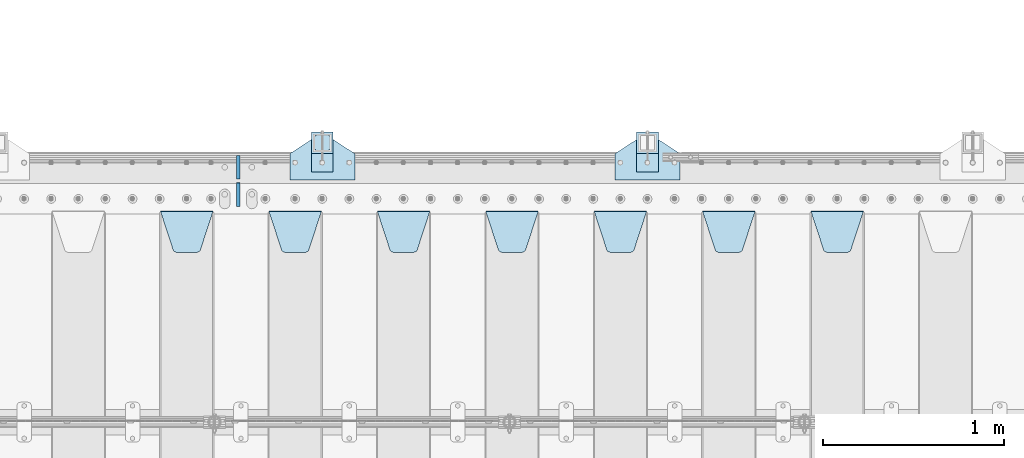
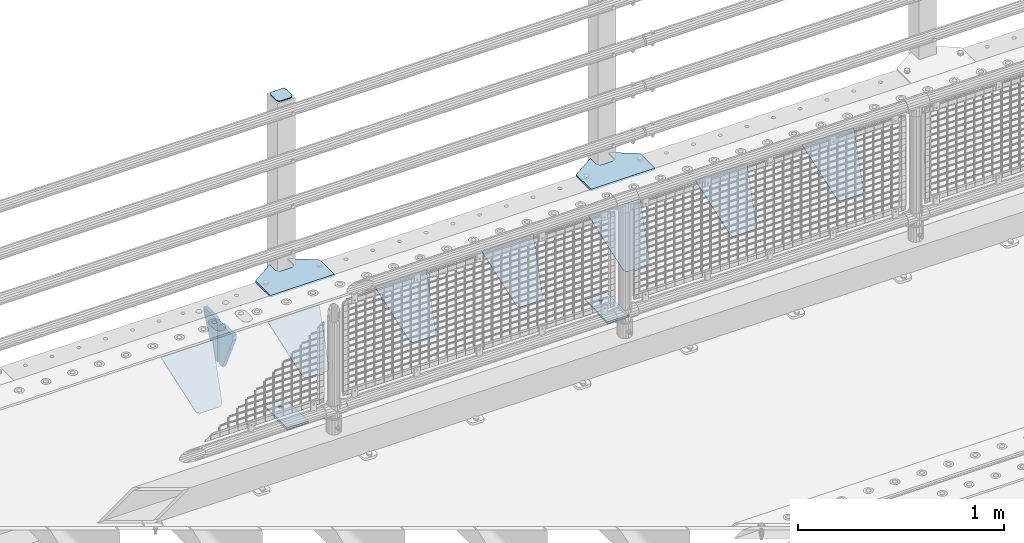
# One storey, part 212 of 242: 16 plates.
"""IFC2X3 building model written with IfcOpenShell, lengths in millimetres."""

from ifc_helpers import new_model, si_unit, frame, origin_with_axes, place, context, subcontext, project, spatial, faceted_brep, material, type_object, element, save


model = new_model("IFC2X3")

# Units and contexts
model_context = context("Model", 3, precision=1e-05, world=origin_with_axes())
body_context = subcontext(model_context, "Body", "Model", "MODEL_VIEW")
ifc_project = project(units=[si_unit("LENGTHUNIT", "METRE", prefix="MILLI"), si_unit("AREAUNIT", "SQUARE_METRE"), si_unit("VOLUMEUNIT", "CUBIC_METRE"), si_unit("MASSUNIT", "GRAM", prefix="KILO"), si_unit("TIMEUNIT", "SECOND"), si_unit("PLANEANGLEUNIT", "RADIAN"), si_unit("SOLIDANGLEUNIT", "STERADIAN"), si_unit("THERMODYNAMICTEMPERATUREUNIT", "DEGREE_CELSIUS"), si_unit("LUMINOUSINTENSITYUNIT", "LUMEN")], contexts=[model_context])

# Site, building, storey
site_placement = place(None, origin_with_axes())
site = spatial("IfcSite", under=ifc_project, at=site_placement, CompositionType="ELEMENT")
building_placement = place(site_placement, origin_with_axes())
building = spatial("IfcBuilding", under=site, at=building_placement, Name="Standard", CompositionType="ELEMENT")
storey_placement = place(building_placement, origin_with_axes())
storey = spatial("IfcBuildingStorey", under=building, at=storey_placement, Name="Undefined", CompositionType="ELEMENT", Elevation=0.0)

# Plates
ifc_material_1 = material(Name="STEEL/S355J2")
plate_type_1 = type_object("IfcPlateType", PredefinedType="NOTDEFINED")
plate_1_placement = place(storey_placement, frame((-33080.0, -17995.0, 5.00000000004911), z_axis=(0.0, 1.0, 0.0), x_axis=(1.0, 0.0, 0.0)))
element("IfcPlate", 1, at=plate_1_placement, inside=storey, type_object=plate_type_1, material=ifc_material_1, context=body_context, shape_type="Brep", body=[
    faceted_brep([(0.0, -5.0, 0.0), (2.31396552408114e-06, -5.0, 145.0), (2.31396552408114e-06, 5.0, 145.0), (0.0, 5.0, 0.0), (130.0, -5.0, 230.0), (130.0, 5.0, 230.0), (130.0, -5.0, 180.0), (130.0, 5.0, 180.0), (130.48036798992, -5.0, 175.122741949595), (130.48036798992, 5.0, 175.122741949595), (131.903011687216, -5.0, 170.432914190871), (131.903011687216, 5.0, 170.432914190871), (134.213259692435, -5.0, 166.110744174512), (134.213259692435, 5.0, 166.110744174512), (137.322330470335, -5.0, 162.322330470335), (137.322330470335, 5.0, 162.322330470335), (141.110744174512, -5.0, 159.213259692435), (141.110744174512, 5.0, 159.213259692435), (145.432914190871, -5.0, 156.903011687216), (145.432914190871, 5.0, 156.903011687216), (150.122741949595, -5.0, 155.48036798992), (150.122741949595, 5.0, 155.48036798992), (155.0, -5.0, 155.0), (155.0, 5.0, 155.0), (205.0, -5.0, 155.0), (205.0, 5.0, 155.0), (209.877258050405, -5.0, 155.48036798992), (209.877258050405, 5.0, 155.48036798992), (214.567085809129, -5.0, 156.903011687216), (214.567085809129, 5.0, 156.903011687216), (218.889255825488, -5.0, 159.213259692435), (218.889255825488, 5.0, 159.213259692435), (222.677669529665, -5.0, 162.322330470335), (222.677669529665, 5.0, 162.322330470335), (225.786740307565, -5.0, 166.110744174512), (225.786740307565, 5.0, 166.110744174512), (228.096988312784, -5.0, 170.432914190871), (228.096988312784, 5.0, 170.432914190871), (229.51963201008, -5.0, 175.122741949595), (229.51963201008, 5.0, 175.122741949595), (230.0, -5.0, 180.0), (230.0, 5.0, 180.0), (230.0, -5.0, 230.0), (230.0, 5.0, 230.0), (360.0, -5.0, 145.0), (360.0, 5.0, 145.0), (360.0, -5.0, -7.27595761418343e-12), (360.0, 5.0, -7.27595761418343e-12)], [[[0, 1, 2, 3]], [[1, 4, 5, 2]], [[4, 6, 7, 5]], [[6, 8, 9, 7]], [[8, 10, 11, 9]], [[10, 12, 13, 11]], [[12, 14, 15, 13]], [[14, 16, 17, 15]], [[16, 18, 19, 17]], [[18, 20, 21, 19]], [[20, 22, 23, 21]], [[22, 24, 25, 23]], [[24, 26, 27, 25]], [[26, 28, 29, 27]], [[28, 30, 31, 29]], [[30, 32, 33, 31]], [[32, 34, 35, 33]], [[34, 36, 37, 35]], [[36, 38, 39, 37]], [[38, 40, 41, 39]], [[40, 42, 43, 41]], [[42, 44, 45, 43]], [[44, 46, 47, 45]], [[46, 0, 3, 47]], [[5, 7, 9, 11, 13, 15, 17, 19, 21, 23, 25, 27, 29, 31, 33, 35, 37, 39, 41, 43, 45, 47, 3, 2]], [[46, 44, 42, 40, 38, 36, 34, 32, 30, 28, 26, 24, 22, 20, 18, 16, 14, 12, 10, 8, 6, 4, 1, 0]]]),
])
plate_2_placement = place(storey_placement, frame((-34880.0, -17995.0, 5.00000000004911), z_axis=(0.0, 1.0, 0.0), x_axis=(1.0, 0.0, 0.0)))
element("IfcPlate", 2, at=plate_2_placement, inside=storey, type_object=plate_type_1, material=ifc_material_1, context=body_context, shape_type="Brep", body=[
    faceted_brep([(0.0, -5.0, 0.0), (2.31396552408114e-06, -5.0, 145.0), (2.31396552408114e-06, 5.0, 145.0), (0.0, 5.0, 0.0), (130.0, -5.0, 230.0), (130.0, 5.0, 230.0), (130.0, -5.0, 180.0), (130.0, 5.0, 180.0), (130.48036798992, -5.0, 175.122741949595), (130.48036798992, 5.0, 175.122741949595), (131.903011687216, -5.0, 170.432914190871), (131.903011687216, 5.0, 170.432914190871), (134.213259692435, -5.0, 166.110744174512), (134.213259692435, 5.0, 166.110744174512), (137.322330470335, -5.0, 162.322330470335), (137.322330470335, 5.0, 162.322330470335), (141.110744174512, -5.0, 159.213259692435), (141.110744174512, 5.0, 159.213259692435), (145.432914190871, -5.0, 156.903011687216), (145.432914190871, 5.0, 156.903011687216), (150.122741949595, -5.0, 155.48036798992), (150.122741949595, 5.0, 155.48036798992), (155.0, -5.0, 155.0), (155.0, 5.0, 155.0), (205.0, -5.0, 155.0), (205.0, 5.0, 155.0), (209.877258050405, -5.0, 155.48036798992), (209.877258050405, 5.0, 155.48036798992), (214.567085809129, -5.0, 156.903011687216), (214.567085809129, 5.0, 156.903011687216), (218.889255825488, -5.0, 159.213259692435), (218.889255825488, 5.0, 159.213259692435), (222.677669529665, -5.0, 162.322330470335), (222.677669529665, 5.0, 162.322330470335), (225.786740307565, -5.0, 166.110744174512), (225.786740307565, 5.0, 166.110744174512), (228.096988312784, -5.0, 170.432914190871), (228.096988312784, 5.0, 170.432914190871), (229.51963201008, -5.0, 175.122741949595), (229.51963201008, 5.0, 175.122741949595), (230.0, -5.0, 180.0), (230.0, 5.0, 180.0), (230.0, -5.0, 230.0), (230.0, 5.0, 230.0), (360.0, -5.0, 145.0), (360.0, 5.0, 145.0), (360.0, -5.0, -7.27595761418343e-12), (360.0, 5.0, -7.27595761418343e-12)], [[[0, 1, 2, 3]], [[1, 4, 5, 2]], [[4, 6, 7, 5]], [[6, 8, 9, 7]], [[8, 10, 11, 9]], [[10, 12, 13, 11]], [[12, 14, 15, 13]], [[14, 16, 17, 15]], [[16, 18, 19, 17]], [[18, 20, 21, 19]], [[20, 22, 23, 21]], [[22, 24, 25, 23]], [[24, 26, 27, 25]], [[26, 28, 29, 27]], [[28, 30, 31, 29]], [[30, 32, 33, 31]], [[32, 34, 35, 33]], [[34, 36, 37, 35]], [[36, 38, 39, 37]], [[38, 40, 41, 39]], [[40, 42, 43, 41]], [[42, 44, 45, 43]], [[44, 46, 47, 45]], [[46, 0, 3, 47]], [[5, 7, 9, 11, 13, 15, 17, 19, 21, 23, 25, 27, 29, 31, 33, 35, 37, 39, 41, 43, 45, 47, 3, 2]], [[46, 44, 42, 40, 38, 36, 34, 32, 30, 28, 26, 24, 22, 20, 18, 16, 14, 12, 10, 8, 6, 4, 1, 0]]]),
])
plate_type_2 = type_object("IfcPlateType", PredefinedType="NOTDEFINED")
for number, where, z_axis, x_axis in (
    (3, (-32959.9999999999, -17949.9999999998, -850.000000000002), (0.0, 1.0, 0.0), (1.0, 0.0, 0.0)),
    (4, (-34759.9999999999, -17949.9999999998, -850.000000000002), (0.0, 1.0, 0.0), (1.0, 0.0, 0.0)),
):
    element("IfcPlate", number, at=place(storey_placement, frame(where, z_axis=z_axis, x_axis=x_axis)), inside=storey, type_object=plate_type_2, material=ifc_material_1, context=body_context, shape_type="Brep", body=[
        faceted_brep([(66.3639610305399, -5.0, 163.636038969114), (66.3639610305399, 5.0, 163.636038969114), (59.9999999998618, 5.0, 160.999999999793), (59.9999999998618, -5.0, 160.999999999793), (53.6360389691836, 5.0, 163.636038969114), (53.6360389691836, -5.0, 163.636038969114), (50.9999999998618, 5.0, 169.999999999793), (50.9999999998618, -5.0, 169.999999999793), (53.6360389691836, 5.0, 176.363961030471), (53.6360389691836, -5.0, 176.363961030471), (59.9999999998618, 5.0, 178.999999999793), (59.9999999998618, -5.0, 178.999999999793), (66.3639610305399, 5.0, 176.363961030471), (66.3639610305399, -5.0, 176.363961030471), (68.9999999998618, 5.0, 169.999999999793), (68.9999999998618, -5.0, 169.999999999793), (120.0, -5.0, 0.0), (120.0, -5.0, 220.0), (0.0, -5.0, 220.0), (0.0, -5.0, 0.0), (0.0, 5.0, 0.0), (120.0, 5.0, 0.0), (120.0, 5.0, 220.0), (0.0, 5.0, 220.0)], [[[0, 1, 2, 3]], [[3, 2, 4, 5]], [[5, 4, 6, 7]], [[7, 6, 8, 9]], [[9, 8, 10, 11]], [[11, 10, 12, 13]], [[13, 12, 14, 15]], [[15, 14, 1, 0]], [[16, 17, 18, 19], [11, 13, 15, 0, 3, 5, 7, 9]], [[16, 19, 20, 21]], [[17, 16, 21, 22]], [[18, 17, 22, 23]], [[19, 18, 23, 20]], [[22, 21, 20, 23], [2, 1, 14, 12, 10, 8, 6, 4]]]),
    ])
plate_type_3 = type_object("IfcPlateType", PredefinedType="NOTDEFINED")
plate_3_placement = place(storey_placement, frame((-34655.9999999999, -17833.9999999998, 1012.50000000001), z_axis=(0.0, 1.0, 0.0), x_axis=(-1.0, 0.0, 0.0)))
element("IfcPlate", 5, at=plate_3_placement, inside=storey, type_object=plate_type_3, material=ifc_material_1, context=body_context, shape_type="Brep", body=[
    faceted_brep([(0.0, -2.5, 19.0), (0.0, -2.5, 69.0), (0.0, 2.5, 69.0), (0.0, 2.5, 19.0), (0.476369668544066, -2.5, 73.2278977451715), (0.476369668544066, 2.5, 73.2278977451715), (1.88159150985302, -2.5, 77.2437910432345), (1.88159150985302, 2.5, 77.2437910432345), (4.14520183310742, -2.5, 80.8463062353148), (4.14520183310742, 2.5, 80.8463062353148), (7.15369376468516, -2.5, 83.8547981668926), (7.15369376468516, 2.5, 83.8547981668926), (10.7562089567655, -2.5, 86.118408490147), (10.7562089567655, 2.5, 86.118408490147), (14.7721022548285, -2.5, 87.5236303314559), (14.7721022548285, 2.5, 87.5236303314559), (19.0, -2.5, 88.0), (19.0, 2.5, 88.0), (69.0, -2.5, 88.0), (69.0, 2.5, 88.0), (73.2278977451715, -2.5, 87.5236303314559), (73.2278977451715, 2.5, 87.5236303314559), (77.2437910432345, -2.5, 86.118408490147), (77.2437910432345, 2.5, 86.118408490147), (80.8463062353148, -2.5, 83.8547981668926), (80.8463062353148, 2.5, 83.8547981668926), (83.8547981668926, -2.5, 80.8463062353148), (83.8547981668926, 2.5, 80.8463062353148), (86.118408490147, -2.5, 77.2437910432345), (86.118408490147, 2.5, 77.2437910432345), (87.5236303314559, -2.5, 73.2278977451715), (87.5236303314559, 2.5, 73.2278977451715), (88.0, -2.5, 69.0), (88.0, 2.5, 69.0), (88.0, -2.5, 19.0), (88.0, 2.5, 19.0), (87.5236303314559, -2.5, 14.7721022548285), (87.5236303314559, 2.5, 14.7721022548285), (86.118408490147, -2.5, 10.7562089567655), (86.118408490147, 2.5, 10.7562089567655), (83.8547981668926, -2.5, 7.15369376468516), (83.8547981668926, 2.5, 7.15369376468516), (80.8463062353148, -2.5, 4.14520183310742), (80.8463062353148, 2.5, 4.14520183310742), (77.2437910432345, -2.5, 1.88159150985302), (77.2437910432345, 2.5, 1.88159150985302), (73.2278977451715, -2.5, 0.476369668544066), (73.2278977451715, 2.5, 0.476369668544066), (69.0, -2.5, 0.0), (69.0, 2.5, 0.0), (19.0, -2.5, 0.0), (19.0, 2.5, 0.0), (14.7721022548285, -2.5, 0.476369668544066), (14.7721022548285, 2.5, 0.476369668544066), (10.7562089567655, -2.5, 1.88159150985302), (10.7562089567655, 2.5, 1.88159150985302), (7.15369376468516, -2.5, 4.14520183310742), (7.15369376468516, 2.5, 4.14520183310742), (4.14520183310742, -2.5, 7.15369376468516), (4.14520183310742, 2.5, 7.15369376468516), (1.88159150985302, -2.5, 10.7562089567655), (1.88159150985302, 2.5, 10.7562089567655), (0.476369668544066, -2.5, 14.7721022548285), (0.476369668544066, 2.5, 14.7721022548285)], [[[0, 1, 2, 3]], [[1, 4, 5, 2]], [[4, 6, 7, 5]], [[6, 8, 9, 7]], [[8, 10, 11, 9]], [[10, 12, 13, 11]], [[12, 14, 15, 13]], [[14, 16, 17, 15]], [[16, 18, 19, 17]], [[18, 20, 21, 19]], [[20, 22, 23, 21]], [[22, 24, 25, 23]], [[24, 26, 27, 25]], [[26, 28, 29, 27]], [[28, 30, 31, 29]], [[30, 32, 33, 31]], [[32, 34, 35, 33]], [[34, 36, 37, 35]], [[36, 38, 39, 37]], [[38, 40, 41, 39]], [[40, 42, 43, 41]], [[42, 44, 45, 43]], [[44, 46, 47, 45]], [[46, 48, 49, 47]], [[48, 50, 51, 49]], [[50, 52, 53, 51]], [[52, 54, 55, 53]], [[54, 56, 57, 55]], [[56, 58, 59, 57]], [[58, 60, 61, 59]], [[60, 62, 63, 61]], [[62, 0, 3, 63]], [[5, 7, 9, 11, 13, 15, 17, 19, 21, 23, 25, 27, 29, 31, 33, 35, 37, 39, 41, 43, 45, 47, 49, 51, 53, 55, 57, 59, 61, 63, 3, 2]], [[62, 60, 58, 56, 54, 52, 50, 48, 46, 44, 42, 40, 38, 36, 34, 32, 30, 28, 26, 24, 22, 20, 18, 16, 14, 12, 10, 8, 6, 4, 1, 0]]]),
])
plate_type_4 = type_object("IfcPlateType", PredefinedType="NOTDEFINED")
for number, where, z_axis, x_axis in (
    (6, (-32959.9999999999, -17949.9999999998, -857.500000000002), (0.0, 1.0, 0.0), (1.0, 0.0, 0.0)),
    (7, (-34759.9999999999, -17949.9999999998, -857.500000000002), (0.0, 1.0, 0.0), (1.0, 0.0, 0.0)),
):
    element("IfcPlate", number, at=place(storey_placement, frame(where, z_axis=z_axis, x_axis=x_axis)), inside=storey, type_object=plate_type_4, material=ifc_material_1, context=body_context, shape_type="Brep", body=[
        faceted_brep([(0.0, -2.5, 0.0), (0.0, -2.5, 100.0), (0.0, 2.5, 100.0), (0.0, 2.5, 0.0), (120.0, -2.5, 100.0), (120.0, 2.5, 100.0), (120.0, -2.5, 0.0), (120.0, 2.5, 0.0)], [[[0, 1, 2, 3]], [[1, 4, 5, 2]], [[4, 6, 7, 5]], [[6, 0, 3, 7]], [[5, 7, 3, 2]], [[6, 4, 1, 0]]]),
    ])
ifc_material_2 = material(Name="STEEL/S355N")
plate_type_5 = type_object("IfcPlateType", PredefinedType="NOTDEFINED")
plate_4_placement = place(storey_placement, frame((-31995.0, -18168.2322330441, -1.76776695296576), z_axis=(0.0, -0.707106781186547, -0.707106781186548), x_axis=(1.0, 0.0, 0.0)))
element("IfcPlate", 8, at=plate_4_placement, inside=storey, type_object=plate_type_5, material=ifc_material_2, context=body_context, shape_type="Brep", body=[
    faceted_brep([(0.0, -2.5, 0.0), (69.345504679477, -2.50000000000182, 300.171731424829), (69.345504679477, 2.5, 300.171731424829), (0.0, 2.5, 0.0), (70.9274061199576, -2.5, 304.897442415398), (70.9274061199576, 2.5, 304.897442415398), (73.3818627772307, -2.5, 309.234538108525), (73.3818627772307, 2.50000000000182, 309.234538108529), (76.6187032999551, -2.5, 313.023683126101), (76.6187032999551, 2.50000000000182, 313.023683126103), (80.5190132704993, -2.5, 316.12567259537), (80.5190132704993, 2.5, 316.12567259537), (84.9395038596849, -2.5, 318.426546230474), (84.9395038596849, 2.50000000000182, 318.426546230476), (89.7177759439219, -2.49999999999818, 319.841774983273), (89.7177759439219, 2.50000000000182, 319.841774983273), (94.678286292652, -2.5, 320.319366455076), (94.678286292652, 2.5, 320.319366455076), (195.321713707348, -2.5, 320.319366455076), (195.321713707348, 2.5, 320.319366455076), (200.282224056078, -2.5, 319.841774983272), (200.282224056078, 2.50000000000182, 319.841774983273), (205.060496140315, -2.5, 318.426546230474), (205.060496140315, 2.49999999999818, 318.426546230474), (209.480986729501, -2.49999999999818, 316.12567259537), (209.480986729501, 2.5, 316.12567259537), (213.381296700045, -2.5, 313.023683126101), (213.381296700045, 2.49999999999818, 313.023683126101), (216.618137222769, -2.5, 309.234538108525), (216.618137222769, 2.5, 309.234538108523), (219.072593880042, -2.49999999999818, 304.897442415398), (219.072593880042, 2.50000000000182, 304.897442415398), (220.654495320523, -2.50000000000182, 300.171731424829), (220.654495320523, 2.5, 300.171731424829), (290.0, -2.5, 0.0), (290.0, 2.5, -1.81898940354586e-12)], [[[0, 1, 2, 3]], [[1, 4, 5, 2]], [[4, 6, 7, 5]], [[6, 8, 9, 7]], [[8, 10, 11, 9]], [[10, 12, 13, 11]], [[12, 14, 15, 13]], [[14, 16, 17, 15]], [[16, 18, 19, 17]], [[18, 20, 21, 19]], [[20, 22, 23, 21]], [[22, 24, 25, 23]], [[24, 26, 27, 25]], [[26, 28, 29, 27]], [[28, 30, 31, 29]], [[30, 32, 33, 31]], [[32, 34, 35, 33]], [[34, 0, 3, 35]], [[5, 7, 9, 11, 13, 15, 17, 19, 21, 23, 25, 27, 29, 31, 33, 35, 3, 2]], [[34, 32, 30, 28, 26, 24, 22, 20, 18, 16, 14, 12, 10, 8, 6, 4, 1, 0]]]),
])
plate_5_placement = place(storey_placement, frame((-32595.0, -18168.2322330441, -1.76776695296576), z_axis=(0.0, -0.707106781186547, -0.707106781186548), x_axis=(1.0, 0.0, 0.0)))
element("IfcPlate", 9, at=plate_5_placement, inside=storey, type_object=plate_type_5, material=ifc_material_2, context=body_context, shape_type="Brep", body=[
    faceted_brep([(0.0, -2.5, 0.0), (69.345504679477, -2.50000000000182, 300.171731424829), (69.345504679477, 2.5, 300.171731424829), (0.0, 2.5, 0.0), (70.9274061199576, -2.5, 304.897442415398), (70.9274061199576, 2.5, 304.897442415398), (73.3818627772307, -2.5, 309.234538108525), (73.3818627772307, 2.50000000000182, 309.234538108529), (76.6187032999551, -2.5, 313.023683126101), (76.6187032999551, 2.50000000000182, 313.023683126103), (80.5190132704993, -2.5, 316.12567259537), (80.5190132704993, 2.5, 316.12567259537), (84.9395038596849, -2.5, 318.426546230474), (84.9395038596849, 2.50000000000182, 318.426546230476), (89.7177759439219, -2.49999999999818, 319.841774983273), (89.7177759439219, 2.50000000000182, 319.841774983273), (94.678286292652, -2.5, 320.319366455076), (94.678286292652, 2.5, 320.319366455076), (195.321713707348, -2.5, 320.319366455076), (195.321713707348, 2.5, 320.319366455076), (200.282224056078, -2.5, 319.841774983272), (200.282224056078, 2.50000000000182, 319.841774983273), (205.060496140315, -2.5, 318.426546230474), (205.060496140315, 2.49999999999818, 318.426546230474), (209.480986729501, -2.49999999999818, 316.12567259537), (209.480986729501, 2.5, 316.12567259537), (213.381296700045, -2.5, 313.023683126101), (213.381296700045, 2.49999999999818, 313.023683126101), (216.618137222769, -2.5, 309.234538108525), (216.618137222769, 2.5, 309.234538108523), (219.072593880042, -2.49999999999818, 304.897442415398), (219.072593880042, 2.50000000000182, 304.897442415398), (220.654495320523, -2.50000000000182, 300.171731424829), (220.654495320523, 2.5, 300.171731424829), (290.0, -2.5, 0.0), (290.0, 2.5, -1.81898940354586e-12)], [[[0, 1, 2, 3]], [[1, 4, 5, 2]], [[4, 6, 7, 5]], [[6, 8, 9, 7]], [[8, 10, 11, 9]], [[10, 12, 13, 11]], [[12, 14, 15, 13]], [[14, 16, 17, 15]], [[16, 18, 19, 17]], [[18, 20, 21, 19]], [[20, 22, 23, 21]], [[22, 24, 25, 23]], [[24, 26, 27, 25]], [[26, 28, 29, 27]], [[28, 30, 31, 29]], [[30, 32, 33, 31]], [[32, 34, 35, 33]], [[34, 0, 3, 35]], [[5, 7, 9, 11, 13, 15, 17, 19, 21, 23, 25, 27, 29, 31, 33, 35, 3, 2]], [[34, 32, 30, 28, 26, 24, 22, 20, 18, 16, 14, 12, 10, 8, 6, 4, 1, 0]]]),
])
plate_6_placement = place(storey_placement, frame((-33195.0, -18168.2322330441, -1.76776695296576), z_axis=(0.0, -0.707106781186547, -0.707106781186548), x_axis=(1.0, 0.0, 0.0)))
element("IfcPlate", 10, at=plate_6_placement, inside=storey, type_object=plate_type_5, material=ifc_material_2, context=body_context, shape_type="Brep", body=[
    faceted_brep([(0.0, -2.5, 0.0), (69.345504679477, -2.50000000000182, 300.171731424829), (69.345504679477, 2.5, 300.171731424829), (0.0, 2.5, 0.0), (70.9274061199576, -2.5, 304.897442415398), (70.9274061199576, 2.5, 304.897442415398), (73.3818627772307, -2.5, 309.234538108525), (73.3818627772307, 2.50000000000182, 309.234538108529), (76.6187032999551, -2.5, 313.023683126101), (76.6187032999551, 2.50000000000182, 313.023683126103), (80.5190132704993, -2.5, 316.12567259537), (80.5190132704993, 2.5, 316.12567259537), (84.9395038596849, -2.5, 318.426546230474), (84.9395038596849, 2.50000000000182, 318.426546230476), (89.7177759439219, -2.49999999999818, 319.841774983273), (89.7177759439219, 2.50000000000182, 319.841774983273), (94.678286292652, -2.5, 320.319366455076), (94.678286292652, 2.5, 320.319366455076), (195.321713707348, -2.5, 320.319366455076), (195.321713707348, 2.5, 320.319366455076), (200.282224056078, -2.5, 319.841774983272), (200.282224056078, 2.50000000000182, 319.841774983273), (205.060496140315, -2.5, 318.426546230474), (205.060496140315, 2.49999999999818, 318.426546230474), (209.480986729501, -2.49999999999818, 316.12567259537), (209.480986729501, 2.5, 316.12567259537), (213.381296700045, -2.5, 313.023683126101), (213.381296700045, 2.49999999999818, 313.023683126101), (216.618137222769, -2.5, 309.234538108525), (216.618137222769, 2.5, 309.234538108523), (219.072593880042, -2.49999999999818, 304.897442415398), (219.072593880042, 2.50000000000182, 304.897442415398), (220.654495320523, -2.50000000000182, 300.171731424829), (220.654495320523, 2.5, 300.171731424829), (290.0, -2.5, 0.0), (290.0, 2.5, -1.81898940354586e-12)], [[[0, 1, 2, 3]], [[1, 4, 5, 2]], [[4, 6, 7, 5]], [[6, 8, 9, 7]], [[8, 10, 11, 9]], [[10, 12, 13, 11]], [[12, 14, 15, 13]], [[14, 16, 17, 15]], [[16, 18, 19, 17]], [[18, 20, 21, 19]], [[20, 22, 23, 21]], [[22, 24, 25, 23]], [[24, 26, 27, 25]], [[26, 28, 29, 27]], [[28, 30, 31, 29]], [[30, 32, 33, 31]], [[32, 34, 35, 33]], [[34, 0, 3, 35]], [[5, 7, 9, 11, 13, 15, 17, 19, 21, 23, 25, 27, 29, 31, 33, 35, 3, 2]], [[34, 32, 30, 28, 26, 24, 22, 20, 18, 16, 14, 12, 10, 8, 6, 4, 1, 0]]]),
])
plate_7_placement = place(storey_placement, frame((-33795.0, -18168.2322330441, -1.76776695296576), z_axis=(0.0, -0.707106781186547, -0.707106781186548), x_axis=(1.0, 0.0, 0.0)))
element("IfcPlate", 11, at=plate_7_placement, inside=storey, type_object=plate_type_5, material=ifc_material_2, context=body_context, shape_type="Brep", body=[
    faceted_brep([(0.0, -2.5, 0.0), (69.345504679477, -2.50000000000182, 300.171731424829), (69.345504679477, 2.5, 300.171731424829), (0.0, 2.5, 0.0), (70.9274061199576, -2.5, 304.897442415398), (70.9274061199576, 2.5, 304.897442415398), (73.3818627772307, -2.5, 309.234538108525), (73.3818627772307, 2.50000000000182, 309.234538108529), (76.6187032999551, -2.5, 313.023683126101), (76.6187032999551, 2.50000000000182, 313.023683126103), (80.5190132704993, -2.5, 316.12567259537), (80.5190132704993, 2.5, 316.12567259537), (84.9395038596849, -2.5, 318.426546230474), (84.9395038596849, 2.50000000000182, 318.426546230476), (89.7177759439219, -2.49999999999818, 319.841774983273), (89.7177759439219, 2.50000000000182, 319.841774983273), (94.678286292652, -2.5, 320.319366455076), (94.678286292652, 2.5, 320.319366455076), (195.321713707348, -2.5, 320.319366455076), (195.321713707348, 2.5, 320.319366455076), (200.282224056078, -2.5, 319.841774983272), (200.282224056078, 2.50000000000182, 319.841774983273), (205.060496140315, -2.5, 318.426546230474), (205.060496140315, 2.49999999999818, 318.426546230474), (209.480986729501, -2.49999999999818, 316.12567259537), (209.480986729501, 2.5, 316.12567259537), (213.381296700045, -2.5, 313.023683126101), (213.381296700045, 2.49999999999818, 313.023683126101), (216.618137222769, -2.5, 309.234538108525), (216.618137222769, 2.5, 309.234538108523), (219.072593880042, -2.49999999999818, 304.897442415398), (219.072593880042, 2.50000000000182, 304.897442415398), (220.654495320523, -2.50000000000182, 300.171731424829), (220.654495320523, 2.5, 300.171731424829), (290.0, -2.5, 0.0), (290.0, 2.5, -1.81898940354586e-12)], [[[0, 1, 2, 3]], [[1, 4, 5, 2]], [[4, 6, 7, 5]], [[6, 8, 9, 7]], [[8, 10, 11, 9]], [[10, 12, 13, 11]], [[12, 14, 15, 13]], [[14, 16, 17, 15]], [[16, 18, 19, 17]], [[18, 20, 21, 19]], [[20, 22, 23, 21]], [[22, 24, 25, 23]], [[24, 26, 27, 25]], [[26, 28, 29, 27]], [[28, 30, 31, 29]], [[30, 32, 33, 31]], [[32, 34, 35, 33]], [[34, 0, 3, 35]], [[5, 7, 9, 11, 13, 15, 17, 19, 21, 23, 25, 27, 29, 31, 33, 35, 3, 2]], [[34, 32, 30, 28, 26, 24, 22, 20, 18, 16, 14, 12, 10, 8, 6, 4, 1, 0]]]),
])
plate_8_placement = place(storey_placement, frame((-34395.0, -18168.2322330441, -1.76776695296576), z_axis=(0.0, -0.707106781186547, -0.707106781186548), x_axis=(1.0, 0.0, 0.0)))
element("IfcPlate", 12, at=plate_8_placement, inside=storey, type_object=plate_type_5, material=ifc_material_2, context=body_context, shape_type="Brep", body=[
    faceted_brep([(0.0, -2.5, 0.0), (69.345504679477, -2.50000000000182, 300.171731424829), (69.345504679477, 2.5, 300.171731424829), (0.0, 2.5, 0.0), (70.9274061199576, -2.5, 304.897442415398), (70.9274061199576, 2.5, 304.897442415398), (73.3818627772307, -2.5, 309.234538108525), (73.3818627772307, 2.50000000000182, 309.234538108529), (76.6187032999551, -2.5, 313.023683126101), (76.6187032999551, 2.50000000000182, 313.023683126103), (80.5190132704993, -2.5, 316.12567259537), (80.5190132704993, 2.5, 316.12567259537), (84.9395038596849, -2.5, 318.426546230474), (84.9395038596849, 2.50000000000182, 318.426546230476), (89.7177759439219, -2.49999999999818, 319.841774983273), (89.7177759439219, 2.50000000000182, 319.841774983273), (94.678286292652, -2.5, 320.319366455076), (94.678286292652, 2.5, 320.319366455076), (195.321713707348, -2.5, 320.319366455076), (195.321713707348, 2.5, 320.319366455076), (200.282224056078, -2.5, 319.841774983272), (200.282224056078, 2.50000000000182, 319.841774983273), (205.060496140315, -2.5, 318.426546230474), (205.060496140315, 2.49999999999818, 318.426546230474), (209.480986729501, -2.49999999999818, 316.12567259537), (209.480986729501, 2.5, 316.12567259537), (213.381296700045, -2.5, 313.023683126101), (213.381296700045, 2.49999999999818, 313.023683126101), (216.618137222769, -2.5, 309.234538108525), (216.618137222769, 2.5, 309.234538108523), (219.072593880042, -2.49999999999818, 304.897442415398), (219.072593880042, 2.50000000000182, 304.897442415398), (220.654495320523, -2.50000000000182, 300.171731424829), (220.654495320523, 2.5, 300.171731424829), (290.0, -2.5, 0.0), (290.0, 2.5, -1.81898940354586e-12)], [[[0, 1, 2, 3]], [[1, 4, 5, 2]], [[4, 6, 7, 5]], [[6, 8, 9, 7]], [[8, 10, 11, 9]], [[10, 12, 13, 11]], [[12, 14, 15, 13]], [[14, 16, 17, 15]], [[16, 18, 19, 17]], [[18, 20, 21, 19]], [[20, 22, 23, 21]], [[22, 24, 25, 23]], [[24, 26, 27, 25]], [[26, 28, 29, 27]], [[28, 30, 31, 29]], [[30, 32, 33, 31]], [[32, 34, 35, 33]], [[34, 0, 3, 35]], [[5, 7, 9, 11, 13, 15, 17, 19, 21, 23, 25, 27, 29, 31, 33, 35, 3, 2]], [[34, 32, 30, 28, 26, 24, 22, 20, 18, 16, 14, 12, 10, 8, 6, 4, 1, 0]]]),
])
plate_9_placement = place(storey_placement, frame((-34995.0, -18168.2322330441, -1.76776695296576), z_axis=(0.0, -0.707106781186547, -0.707106781186548), x_axis=(1.0, 0.0, 0.0)))
element("IfcPlate", 13, at=plate_9_placement, inside=storey, type_object=plate_type_5, material=ifc_material_2, context=body_context, shape_type="Brep", body=[
    faceted_brep([(0.0, -2.5, 0.0), (69.345504679477, -2.50000000000182, 300.171731424829), (69.345504679477, 2.5, 300.171731424829), (0.0, 2.5, 0.0), (70.9274061199576, -2.5, 304.897442415398), (70.9274061199576, 2.5, 304.897442415398), (73.3818627772307, -2.5, 309.234538108525), (73.3818627772307, 2.50000000000182, 309.234538108529), (76.6187032999551, -2.5, 313.023683126101), (76.6187032999551, 2.50000000000182, 313.023683126103), (80.5190132704993, -2.5, 316.12567259537), (80.5190132704993, 2.5, 316.12567259537), (84.9395038596849, -2.5, 318.426546230474), (84.9395038596849, 2.50000000000182, 318.426546230476), (89.7177759439219, -2.49999999999818, 319.841774983273), (89.7177759439219, 2.50000000000182, 319.841774983273), (94.678286292652, -2.5, 320.319366455076), (94.678286292652, 2.5, 320.319366455076), (195.321713707348, -2.5, 320.319366455076), (195.321713707348, 2.5, 320.319366455076), (200.282224056078, -2.5, 319.841774983272), (200.282224056078, 2.50000000000182, 319.841774983273), (205.060496140315, -2.5, 318.426546230474), (205.060496140315, 2.49999999999818, 318.426546230474), (209.480986729501, -2.49999999999818, 316.12567259537), (209.480986729501, 2.5, 316.12567259537), (213.381296700045, -2.5, 313.023683126101), (213.381296700045, 2.49999999999818, 313.023683126101), (216.618137222769, -2.5, 309.234538108525), (216.618137222769, 2.5, 309.234538108523), (219.072593880042, -2.49999999999818, 304.897442415398), (219.072593880042, 2.50000000000182, 304.897442415398), (220.654495320523, -2.50000000000182, 300.171731424829), (220.654495320523, 2.5, 300.171731424829), (290.0, -2.5, 0.0), (290.0, 2.5, -1.81898940354586e-12)], [[[0, 1, 2, 3]], [[1, 4, 5, 2]], [[4, 6, 7, 5]], [[6, 8, 9, 7]], [[8, 10, 11, 9]], [[10, 12, 13, 11]], [[12, 14, 15, 13]], [[14, 16, 17, 15]], [[16, 18, 19, 17]], [[18, 20, 21, 19]], [[20, 22, 23, 21]], [[22, 24, 25, 23]], [[24, 26, 27, 25]], [[26, 28, 29, 27]], [[28, 30, 31, 29]], [[30, 32, 33, 31]], [[32, 34, 35, 33]], [[34, 0, 3, 35]], [[5, 7, 9, 11, 13, 15, 17, 19, 21, 23, 25, 27, 29, 31, 33, 35, 3, 2]], [[34, 32, 30, 28, 26, 24, 22, 20, 18, 16, 14, 12, 10, 8, 6, 4, 1, 0]]]),
])
plate_10_placement = place(storey_placement, frame((-35595.0, -18168.2322330441, -1.76776695296576), z_axis=(0.0, -0.707106781186547, -0.707106781186548), x_axis=(1.0, 0.0, 0.0)))
element("IfcPlate", 14, at=plate_10_placement, inside=storey, type_object=plate_type_5, material=ifc_material_2, context=body_context, shape_type="Brep", body=[
    faceted_brep([(0.0, -2.5, 0.0), (69.345504679477, -2.50000000000182, 300.171731424829), (69.345504679477, 2.5, 300.171731424829), (0.0, 2.5, 0.0), (70.9274061199576, -2.5, 304.897442415398), (70.9274061199576, 2.5, 304.897442415398), (73.3818627772307, -2.5, 309.234538108525), (73.3818627772307, 2.50000000000182, 309.234538108529), (76.6187032999551, -2.5, 313.023683126101), (76.6187032999551, 2.50000000000182, 313.023683126103), (80.5190132704993, -2.5, 316.12567259537), (80.5190132704993, 2.5, 316.12567259537), (84.9395038596849, -2.5, 318.426546230474), (84.9395038596849, 2.50000000000182, 318.426546230476), (89.7177759439219, -2.49999999999818, 319.841774983273), (89.7177759439219, 2.50000000000182, 319.841774983273), (94.678286292652, -2.5, 320.319366455076), (94.678286292652, 2.5, 320.319366455076), (195.321713707348, -2.5, 320.319366455076), (195.321713707348, 2.5, 320.319366455076), (200.282224056078, -2.5, 319.841774983272), (200.282224056078, 2.50000000000182, 319.841774983273), (205.060496140315, -2.5, 318.426546230474), (205.060496140315, 2.49999999999818, 318.426546230474), (209.480986729501, -2.49999999999818, 316.12567259537), (209.480986729501, 2.5, 316.12567259537), (213.381296700045, -2.5, 313.023683126101), (213.381296700045, 2.49999999999818, 313.023683126101), (216.618137222769, -2.5, 309.234538108525), (216.618137222769, 2.5, 309.234538108523), (219.072593880042, -2.49999999999818, 304.897442415398), (219.072593880042, 2.50000000000182, 304.897442415398), (220.654495320523, -2.50000000000182, 300.171731424829), (220.654495320523, 2.5, 300.171731424829), (290.0, -2.5, 0.0), (290.0, 2.5, -1.81898940354586e-12)], [[[0, 1, 2, 3]], [[1, 4, 5, 2]], [[4, 6, 7, 5]], [[6, 8, 9, 7]], [[8, 10, 11, 9]], [[10, 12, 13, 11]], [[12, 14, 15, 13]], [[14, 16, 17, 15]], [[16, 18, 19, 17]], [[18, 20, 21, 19]], [[20, 22, 23, 21]], [[22, 24, 25, 23]], [[24, 26, 27, 25]], [[26, 28, 29, 27]], [[28, 30, 31, 29]], [[30, 32, 33, 31]], [[32, 34, 35, 33]], [[34, 0, 3, 35]], [[5, 7, 9, 11, 13, 15, 17, 19, 21, 23, 25, 27, 29, 31, 33, 35, 3, 2]], [[34, 32, 30, 28, 26, 24, 22, 20, 18, 16, 14, 12, 10, 8, 6, 4, 1, 0]]]),
])
plate_type_6 = type_object("IfcPlateType", PredefinedType="NOTDEFINED")
for number, where, z_axis, x_axis in (
    (15, (-35165.0, -17858.75, -35.0), (0.0, 0.0, -1.0), (0.0, -1.0, 0.0)),
    (16, (-35165.0, -18141.25, -35.0), (0.0, 0.0, -1.0), (0.0, 1.0, 0.0)),
):
    element("IfcPlate", number, at=place(storey_placement, frame(where, z_axis=z_axis, x_axis=x_axis)), inside=storey, type_object=plate_type_6, material=ifc_material_2, context=body_context, shape_type="Brep", body=[
        faceted_brep([(0.0, -10.0, 0.0), (0.0, -10.0, 30.0), (0.0, 10.0, 30.0), (0.0, 10.0, 0.0), (102.0, -10.0, 250.0), (102.0, 10.0, 250.0), (132.0, -10.0, 250.0), (132.0, 10.0, 250.0), (132.0, -10.0, 30.0), (132.0, 10.0, 30.0), (131.544232590368, -10.0, 24.790554669992), (131.544232590368, 10.0, 24.790554669992), (130.190778623579, -10.0, 19.7393957002299), (130.190778623579, 10.0, 19.7393957002299), (127.980762113533, -10.0, 15.0), (127.980762113533, 10.0, 15.0), (124.98133329357, -10.0, 10.7163717094038), (124.98133329357, 10.0, 10.7163717094038), (121.283628290596, -10.0, 7.01866670643062), (121.283628290596, 10.0, 7.01866670643062), (117.0, -10.0, 4.01923788646684), (117.0, 10.0, 4.01923788646684), (112.260604299769, -10.0, 1.80922137642278), (112.260604299769, 10.0, 1.80922137642278), (107.209445330009, -10.0, 0.455767409633722), (107.209445330009, 10.0, 0.455767409633722), (102.0, -10.0, 0.0), (102.0, 10.0, 0.0)], [[[0, 1, 2, 3]], [[1, 4, 5, 2]], [[4, 6, 7, 5]], [[6, 8, 9, 7]], [[8, 10, 11, 9]], [[10, 12, 13, 11]], [[12, 14, 15, 13]], [[14, 16, 17, 15]], [[16, 18, 19, 17]], [[18, 20, 21, 19]], [[20, 22, 23, 21]], [[22, 24, 25, 23]], [[24, 26, 27, 25]], [[26, 0, 3, 27]], [[5, 7, 9, 11, 13, 15, 17, 19, 21, 23, 25, 27, 3, 2]], [[26, 24, 22, 20, 18, 16, 14, 12, 10, 8, 6, 4, 1, 0]]]),
    ])

save(model, "model.ifc")
